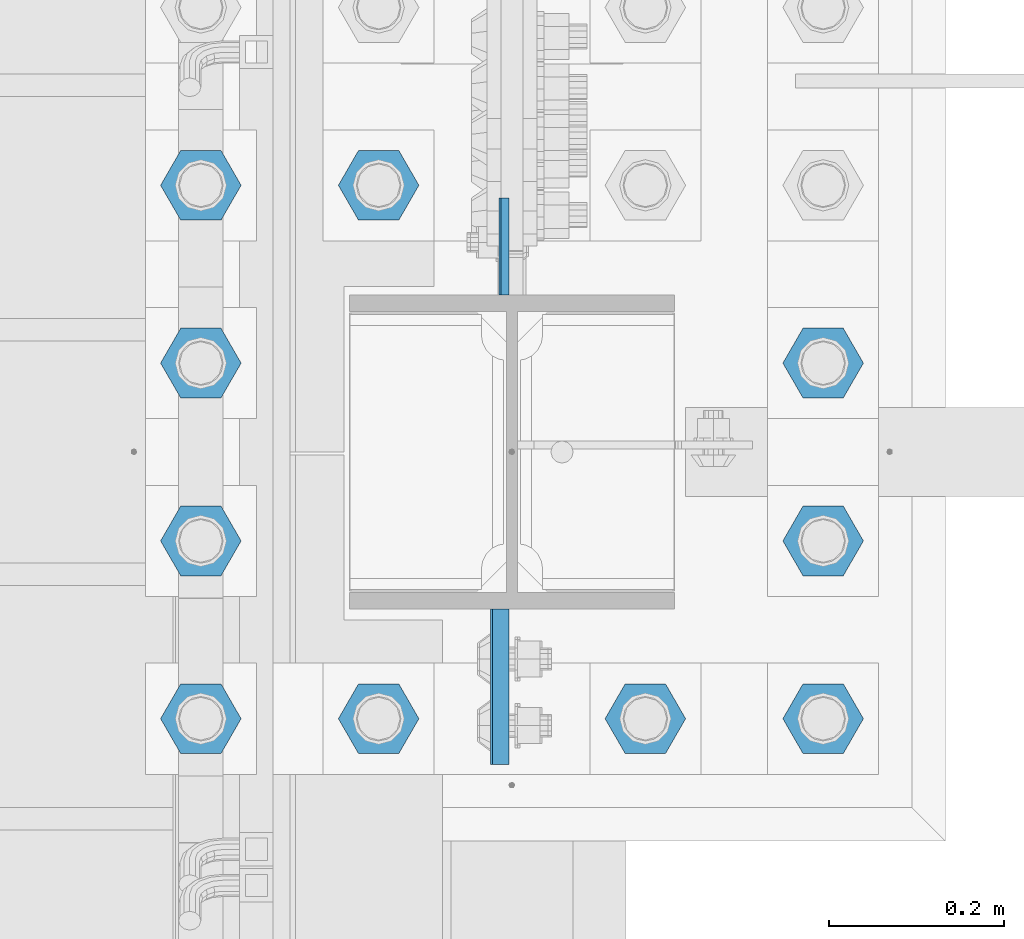
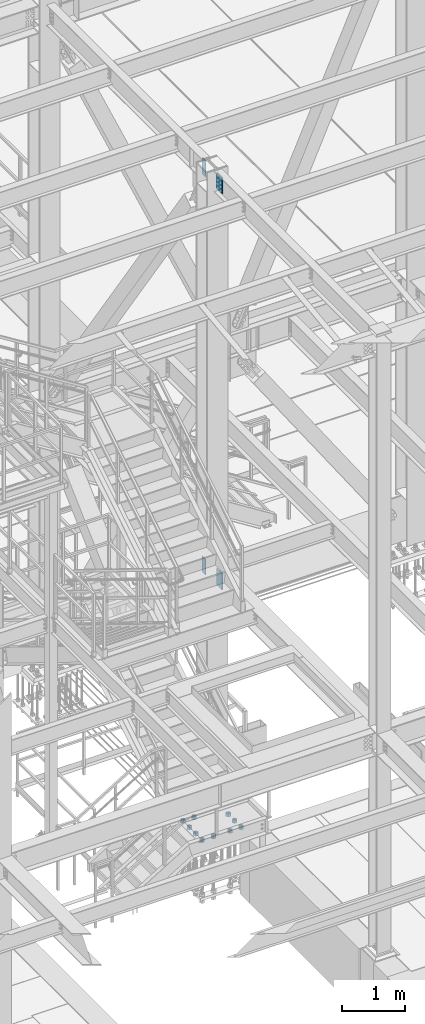
# One storey, part 1480 of 3843: 14 columns, 2 elements without a shape of their own.
"""IFC2X3 building model written with IfcOpenShell, lengths in millimetres."""

from ifc_helpers import new_model, si_unit, frame, origin_with_axes, place, context, subcontext, project, spatial, faceted_brep, material, type_object, element, aggregate, save


model = new_model("IFC2X3")

# Units and contexts
model_context = context("Model", 3, precision=1e-05, world=origin_with_axes())
body_context = subcontext(model_context, "Body", "Model", "MODEL_VIEW")
ifc_project = project(units=[si_unit("LENGTHUNIT", "METRE", prefix="MILLI"), si_unit("AREAUNIT", "SQUARE_METRE"), si_unit("VOLUMEUNIT", "CUBIC_METRE"), si_unit("MASSUNIT", "GRAM", prefix="KILO"), si_unit("TIMEUNIT", "SECOND"), si_unit("PLANEANGLEUNIT", "RADIAN"), si_unit("SOLIDANGLEUNIT", "STERADIAN"), si_unit("THERMODYNAMICTEMPERATUREUNIT", "DEGREE_CELSIUS"), si_unit("LUMINOUSINTENSITYUNIT", "LUMEN")], contexts=[model_context])

# Site, building, storey
site_placement = place(None, origin_with_axes())
site = spatial("IfcSite", under=ifc_project, at=site_placement, CompositionType="ELEMENT")
building_placement = place(site_placement, origin_with_axes())
building = spatial("IfcBuilding", under=site, at=building_placement, Name="Undefined", CompositionType="ELEMENT")
storey_placement = place(building_placement, origin_with_axes())
storey = spatial("IfcBuildingStorey", under=building, at=storey_placement, Name="Undefined", CompositionType="ELEMENT", Elevation=0.0)

# Assembly, columns
assembly_1_placement = place(storey_placement, origin_with_axes())
assembly_1 = element("IfcElementAssembly", 1, at=assembly_1_placement, inside=storey, Name="COLUMN", AssemblyPlace="NOTDEFINED", PredefinedType="RIGID_FRAME")
ifc_material_1 = material(Name="STEEL/A572-50")
column_type_1 = type_object("IfcColumnType", PredefinedType="NOTDEFINED")
column_1_placement = place(assembly_1_placement, frame((55922.8625, 20542.25, 42108.4374991957), z_axis=(0.0, -1.0, 0.0), x_axis=(0.0, 0.0, 1.0)))
column_1 = element("IfcColumn", 2, at=column_1_placement, type_object=column_type_1, material=ifc_material_1, Name="PLATE", context=body_context, shape_type="Brep", body=[
    faceted_brep([(0.0, 4.76249999999709, -55.5625), (0.0, 4.76249999999709, 55.5625), (317.5, 4.76249999999709, 55.5625), (317.5, 4.76249999999709, -55.5625), (0.0, -4.76249999999709, 55.5625), (317.5, -4.76249999999709, 55.5625), (0.0, -4.76249999999709, -55.5625), (317.5, -4.76249999999709, -55.5625)], [[[0, 1, 2, 3]], [[1, 4, 5, 2]], [[4, 6, 7, 5]], [[6, 0, 3, 7]], [[5, 7, 3, 2]], [[6, 4, 1, 0]]]),
])
column_2_placement = place(assembly_1_placement, frame((55920.48125, 20542.25, 34426.525), z_axis=(0.0, -1.0, 0.0), x_axis=(0.0, 0.0, 1.0)))
column_2 = element("IfcColumn", 3, at=column_2_placement, type_object=column_type_1, material=ifc_material_1, Name="PLATE", context=body_context, shape_type="Brep", body=[
    faceted_brep([(0.0, 4.76249999999709, -55.5625), (0.0, 4.76249999999709, 55.5625), (304.800000000003, 4.76249999999709, 55.5625), (304.800000000003, 4.76249999999709, -55.5625), (0.0, -4.76249999999709, 55.5625), (304.800000000003, -4.76249999999709, 55.5625), (0.0, -4.76249999999709, -55.5625), (304.800000000003, -4.76249999999709, -55.5625)], [[[0, 1, 2, 3]], [[1, 4, 5, 2]], [[4, 6, 7, 5]], [[6, 0, 3, 7]], [[5, 7, 3, 2]], [[6, 4, 1, 0]]]),
])
column_type_2 = type_object("IfcColumnType", PredefinedType="NOTDEFINED")
column_3_placement = place(assembly_1_placement, frame((55918.1, 20039.0125, 42113.1999993376), z_axis=(0.0, 1.0, 0.0), x_axis=(0.0, 0.0, 1.0)))
column_3 = element("IfcColumn", 4, at=column_3_placement, type_object=column_type_2, material=ifc_material_1, Name="PLATE", context=body_context, shape_type="Brep", body=[
    faceted_brep([(0.0, 9.52500000000146, -88.9000000000015), (0.0, 9.52500000000146, 88.9000000000015), (317.5, 9.52500000000146, 88.9000000000015), (317.5, 9.52500000000146, -88.9000000000015), (0.0, -9.52500000000146, 88.9000000000015), (317.5, -9.52500000000146, 88.9000000000015), (0.0, -9.52500000000146, -88.9000000000015), (317.5, -9.52500000000146, -88.9000000000015)], [[[0, 1, 2, 3]], [[1, 4, 5, 2]], [[4, 6, 7, 5]], [[6, 0, 3, 7]], [[5, 7, 3, 2]], [[6, 4, 1, 0]]]),
])
column_4_placement = place(assembly_1_placement, frame((55915.71875, 20039.0125, 34461.4499993376), z_axis=(0.0, 1.0, 0.0), x_axis=(0.0, 0.0, 1.0)))
column_4 = element("IfcColumn", 5, at=column_4_placement, type_object=column_type_2, material=ifc_material_1, Name="PLATE", context=body_context, shape_type="Brep", body=[
    faceted_brep([(0.0, 9.52500000000146, -88.9000000000015), (0.0, 9.52500000000146, 88.9000000000015), (317.5, 9.52500000000146, 88.9000000000015), (317.5, 9.52500000000146, -88.9000000000015), (0.0, -9.52500000000146, 88.9000000000015), (317.5, -9.52500000000146, 88.9000000000015), (0.0, -9.52500000000146, -88.9000000000015), (317.5, -9.52500000000146, -88.9000000000015)], [[[0, 1, 2, 3]], [[1, 4, 5, 2]], [[4, 6, 7, 5]], [[6, 0, 3, 7]], [[5, 7, 3, 2]], [[6, 4, 1, 0]]]),
])
aggregate(assembly_1, [column_1, column_3, column_2, column_4])

assembly_2_placement = place(storey_placement, origin_with_axes())
assembly_2 = element("IfcElementAssembly", 6, at=assembly_2_placement, inside=storey, Name="TEMPLATE", AssemblyPlace="NOTDEFINED", PredefinedType="RIGID_FRAME")
ifc_material_2 = material(Name="STEEL/A36")
column_type_3 = type_object("IfcColumnType", Name="2_HEAVY_HEX_NUT", PredefinedType="NOTDEFINED")
column_5_placement = place(assembly_2_placement, frame((55575.2, 20002.5, 29749.75), z_axis=(0.0, -1.0, 0.0), x_axis=(0.0, 0.0, -1.0)))
column_5 = element("IfcColumn", 7, at=column_5_placement, type_object=column_type_3, material=ifc_material_2, Name="NUT", ObjectType="2_HEAVY_HEX_NUT", context=body_context, shape_type="Brep", body=[
    faceted_brep([(0.0, -46.0369987487793, 0.0), (0.0, -23.0184993743896, -39.869213104248), (50.7999999999993, -23.0184993743896, -39.869213104248), (50.7999999999993, -46.0369987487793, 0.0), (0.0, 23.0184993743896, -39.869213104248), (50.7999999999993, 23.0184993743896, -39.869213104248), (0.0, 46.0369987487793, 0.0), (50.7999999999993, 46.0369987487793, 0.0), (0.0, 23.0184993743896, 39.869213104248), (50.7999999999993, 23.0184993743896, 39.869213104248), (0.0, -23.0184993743896, 39.869213104248), (50.7999999999993, -23.0184993743896, 39.869213104248), (0.0, 0.0, 26.1940002441406), (0.0, 11.3650617044477, 23.5999013092805), (50.7999999999993, 11.3650617044477, 23.5999013092805), (50.7999999999993, 0.0, 26.1940002441406), (0.0, 20.4791109456419, 16.3316083006721), (50.7999999999993, 20.4791109456419, 16.3316083006721), (0.0, 25.5370200498292, 5.82867859874386), (50.7999999999993, 25.5370200498292, 5.82867859874386), (0.0, 25.5370200498292, -5.82867859874386), (50.7999999999993, 25.5370200498292, -5.82867859874386), (0.0, 20.4791109456419, -16.3316083006721), (50.7999999999993, 20.4791109456419, -16.3316083006721), (0.0, 11.3650617044477, -23.5999013092805), (50.7999999999993, 11.3650617044477, -23.5999013092805), (0.0, 0.0, -26.1940002441406), (50.7999999999993, 0.0, -26.1940002441406), (0.0, -11.3650617044477, -23.5999013092805), (50.7999999999993, -11.3650617044477, -23.5999013092805), (0.0, -20.4791109456419, -16.3316083006721), (50.7999999999993, -20.4791109456419, -16.3316083006721), (0.0, -25.5370200498292, -5.82867859874386), (50.7999999999993, -25.5370200498292, -5.82867859874386), (0.0, -25.5370200498292, 5.82867859874386), (50.7999999999993, -25.5370200498292, 5.82867859874386), (0.0, -20.4791109456419, 16.3316083006721), (50.7999999999993, -20.4791109456419, 16.3316083006721), (0.0, -11.3650617044477, 23.5999013092805), (50.7999999999993, -11.3650617044477, 23.5999013092805)], [[[0, 1, 2, 3]], [[1, 4, 5, 2]], [[4, 6, 7, 5]], [[6, 8, 9, 7]], [[8, 10, 11, 9]], [[10, 0, 3, 11]], [[12, 13, 14, 15]], [[13, 16, 17, 14]], [[16, 18, 19, 17]], [[18, 20, 21, 19]], [[20, 22, 23, 21]], [[22, 24, 25, 23]], [[24, 26, 27, 25]], [[26, 28, 29, 27]], [[28, 30, 31, 29]], [[30, 32, 33, 31]], [[32, 34, 35, 33]], [[34, 36, 37, 35]], [[36, 38, 39, 37]], [[38, 12, 15, 39]], [[5, 7, 9, 11, 3, 2], [17, 19, 21, 23, 25, 27, 29, 31, 33, 35, 37, 39, 15, 14]], [[10, 8, 6, 4, 1, 0], [38, 36, 34, 32, 30, 28, 26, 24, 22, 20, 18, 16, 13, 12]]]),
])
column_6_placement = place(assembly_2_placement, frame((55778.4, 20002.5, 29749.75), z_axis=(0.0, -1.0, 0.0), x_axis=(0.0, 0.0, -1.0)))
column_6 = element("IfcColumn", 8, at=column_6_placement, type_object=column_type_3, material=ifc_material_2, Name="NUT", ObjectType="2_HEAVY_HEX_NUT", context=body_context, shape_type="Brep", body=[
    faceted_brep([(0.0, -46.0369987487793, 0.0), (0.0, -23.0184993743896, -39.869213104248), (50.7999999999993, -23.0184993743896, -39.869213104248), (50.7999999999993, -46.0369987487793, 0.0), (0.0, 23.0184993743896, -39.869213104248), (50.7999999999993, 23.0184993743896, -39.869213104248), (0.0, 46.0369987487793, 0.0), (50.7999999999993, 46.0369987487793, 0.0), (0.0, 23.0184993743896, 39.869213104248), (50.7999999999993, 23.0184993743896, 39.869213104248), (0.0, -23.0184993743896, 39.869213104248), (50.7999999999993, -23.0184993743896, 39.869213104248), (0.0, 0.0, 26.1940002441406), (0.0, 11.3650617044477, 23.5999013092805), (50.7999999999993, 11.3650617044477, 23.5999013092805), (50.7999999999993, 0.0, 26.1940002441406), (0.0, 20.4791109456419, 16.3316083006721), (50.7999999999993, 20.4791109456419, 16.3316083006721), (0.0, 25.5370200498292, 5.82867859874386), (50.7999999999993, 25.5370200498292, 5.82867859874386), (0.0, 25.5370200498292, -5.82867859874386), (50.7999999999993, 25.5370200498292, -5.82867859874386), (0.0, 20.4791109456419, -16.3316083006721), (50.7999999999993, 20.4791109456419, -16.3316083006721), (0.0, 11.3650617044477, -23.5999013092805), (50.7999999999993, 11.3650617044477, -23.5999013092805), (0.0, 0.0, -26.1940002441406), (50.7999999999993, 0.0, -26.1940002441406), (0.0, -11.3650617044477, -23.5999013092805), (50.7999999999993, -11.3650617044477, -23.5999013092805), (0.0, -20.4791109456419, -16.3316083006721), (50.7999999999993, -20.4791109456419, -16.3316083006721), (0.0, -25.5370200498292, -5.82867859874386), (50.7999999999993, -25.5370200498292, -5.82867859874386), (0.0, -25.5370200498292, 5.82867859874386), (50.7999999999993, -25.5370200498292, 5.82867859874386), (0.0, -20.4791109456419, 16.3316083006721), (50.7999999999993, -20.4791109456419, 16.3316083006721), (0.0, -11.3650617044477, 23.5999013092805), (50.7999999999993, -11.3650617044477, 23.5999013092805)], [[[0, 1, 2, 3]], [[1, 4, 5, 2]], [[4, 6, 7, 5]], [[6, 8, 9, 7]], [[8, 10, 11, 9]], [[10, 0, 3, 11]], [[12, 13, 14, 15]], [[13, 16, 17, 14]], [[16, 18, 19, 17]], [[18, 20, 21, 19]], [[20, 22, 23, 21]], [[22, 24, 25, 23]], [[24, 26, 27, 25]], [[26, 28, 29, 27]], [[28, 30, 31, 29]], [[30, 32, 33, 31]], [[32, 34, 35, 33]], [[34, 36, 37, 35]], [[36, 38, 39, 37]], [[38, 12, 15, 39]], [[5, 7, 9, 11, 3, 2], [17, 19, 21, 23, 25, 27, 29, 31, 33, 35, 37, 39, 15, 14]], [[10, 8, 6, 4, 1, 0], [38, 36, 34, 32, 30, 28, 26, 24, 22, 20, 18, 16, 13, 12]]]),
])
column_7_placement = place(assembly_2_placement, frame((56083.2, 20002.5, 29749.75), z_axis=(0.0, 1.0, 0.0), x_axis=(0.0, 0.0, -1.0)))
column_7 = element("IfcColumn", 9, at=column_7_placement, type_object=column_type_3, material=ifc_material_2, Name="NUT", ObjectType="2_HEAVY_HEX_NUT", context=body_context, shape_type="Brep", body=[
    faceted_brep([(0.0, -46.0369987487793, 0.0), (0.0, -23.0184993743896, -39.869213104248), (50.7999999999993, -23.0184993743896, -39.869213104248), (50.7999999999993, -46.0369987487793, 0.0), (0.0, 23.0184993743896, -39.869213104248), (50.7999999999993, 23.0184993743896, -39.869213104248), (0.0, 46.0369987487793, 0.0), (50.7999999999993, 46.0369987487793, 0.0), (0.0, 23.0184993743896, 39.869213104248), (50.7999999999993, 23.0184993743896, 39.869213104248), (0.0, -23.0184993743896, 39.869213104248), (50.7999999999993, -23.0184993743896, 39.869213104248), (0.0, 0.0, 26.1940002441406), (0.0, 11.3650617044477, 23.5999013092805), (50.7999999999993, 11.3650617044477, 23.5999013092805), (50.7999999999993, 0.0, 26.1940002441406), (0.0, 20.4791109456419, 16.3316083006721), (50.7999999999993, 20.4791109456419, 16.3316083006721), (0.0, 25.5370200498292, 5.82867859874386), (50.7999999999993, 25.5370200498292, 5.82867859874386), (0.0, 25.5370200498292, -5.82867859874386), (50.7999999999993, 25.5370200498292, -5.82867859874386), (0.0, 20.4791109456419, -16.3316083006721), (50.7999999999993, 20.4791109456419, -16.3316083006721), (0.0, 11.3650617044477, -23.5999013092805), (50.7999999999993, 11.3650617044477, -23.5999013092805), (0.0, 0.0, -26.1940002441406), (50.7999999999993, 0.0, -26.1940002441406), (0.0, -11.3650617044477, -23.5999013092805), (50.7999999999993, -11.3650617044477, -23.5999013092805), (0.0, -20.4791109456419, -16.3316083006721), (50.7999999999993, -20.4791109456419, -16.3316083006721), (0.0, -25.5370200498292, -5.82867859874386), (50.7999999999993, -25.5370200498292, -5.82867859874386), (0.0, -25.5370200498292, 5.82867859874386), (50.7999999999993, -25.5370200498292, 5.82867859874386), (0.0, -20.4791109456419, 16.3316083006721), (50.7999999999993, -20.4791109456419, 16.3316083006721), (0.0, -11.3650617044477, 23.5999013092805), (50.7999999999993, -11.3650617044477, 23.5999013092805)], [[[0, 1, 2, 3]], [[1, 4, 5, 2]], [[4, 6, 7, 5]], [[6, 8, 9, 7]], [[8, 10, 11, 9]], [[10, 0, 3, 11]], [[12, 13, 14, 15]], [[13, 16, 17, 14]], [[16, 18, 19, 17]], [[18, 20, 21, 19]], [[20, 22, 23, 21]], [[22, 24, 25, 23]], [[24, 26, 27, 25]], [[26, 28, 29, 27]], [[28, 30, 31, 29]], [[30, 32, 33, 31]], [[32, 34, 35, 33]], [[34, 36, 37, 35]], [[36, 38, 39, 37]], [[38, 12, 15, 39]], [[5, 7, 9, 11, 3, 2], [17, 19, 21, 23, 25, 27, 29, 31, 33, 35, 37, 39, 15, 14]], [[10, 8, 6, 4, 1, 0], [38, 36, 34, 32, 30, 28, 26, 24, 22, 20, 18, 16, 13, 12]]]),
])
column_8_placement = place(assembly_2_placement, frame((56286.4, 20002.5, 29749.75), z_axis=(0.0, 1.0, 0.0), x_axis=(0.0, 0.0, -1.0)))
column_8 = element("IfcColumn", 10, at=column_8_placement, type_object=column_type_3, material=ifc_material_2, Name="NUT", ObjectType="2_HEAVY_HEX_NUT", context=body_context, shape_type="Brep", body=[
    faceted_brep([(0.0, -46.0369987487793, 0.0), (0.0, -23.0184993743896, -39.869213104248), (50.7999999999993, -23.0184993743896, -39.869213104248), (50.7999999999993, -46.0369987487793, 0.0), (0.0, 23.0184993743896, -39.869213104248), (50.7999999999993, 23.0184993743896, -39.869213104248), (0.0, 46.0369987487793, 0.0), (50.7999999999993, 46.0369987487793, 0.0), (0.0, 23.0184993743896, 39.869213104248), (50.7999999999993, 23.0184993743896, 39.869213104248), (0.0, -23.0184993743896, 39.869213104248), (50.7999999999993, -23.0184993743896, 39.869213104248), (0.0, 0.0, 26.1940002441406), (0.0, 11.3650617044477, 23.5999013092805), (50.7999999999993, 11.3650617044477, 23.5999013092805), (50.7999999999993, 0.0, 26.1940002441406), (0.0, 20.4791109456419, 16.3316083006721), (50.7999999999993, 20.4791109456419, 16.3316083006721), (0.0, 25.5370200498292, 5.82867859874386), (50.7999999999993, 25.5370200498292, 5.82867859874386), (0.0, 25.5370200498292, -5.82867859874386), (50.7999999999993, 25.5370200498292, -5.82867859874386), (0.0, 20.4791109456419, -16.3316083006721), (50.7999999999993, 20.4791109456419, -16.3316083006721), (0.0, 11.3650617044477, -23.5999013092805), (50.7999999999993, 11.3650617044477, -23.5999013092805), (0.0, 0.0, -26.1940002441406), (50.7999999999993, 0.0, -26.1940002441406), (0.0, -11.3650617044477, -23.5999013092805), (50.7999999999993, -11.3650617044477, -23.5999013092805), (0.0, -20.4791109456419, -16.3316083006721), (50.7999999999993, -20.4791109456419, -16.3316083006721), (0.0, -25.5370200498292, -5.82867859874386), (50.7999999999993, -25.5370200498292, -5.82867859874386), (0.0, -25.5370200498292, 5.82867859874386), (50.7999999999993, -25.5370200498292, 5.82867859874386), (0.0, -20.4791109456419, 16.3316083006721), (50.7999999999993, -20.4791109456419, 16.3316083006721), (0.0, -11.3650617044477, 23.5999013092805), (50.7999999999993, -11.3650617044477, 23.5999013092805)], [[[0, 1, 2, 3]], [[1, 4, 5, 2]], [[4, 6, 7, 5]], [[6, 8, 9, 7]], [[8, 10, 11, 9]], [[10, 0, 3, 11]], [[12, 13, 14, 15]], [[13, 16, 17, 14]], [[16, 18, 19, 17]], [[18, 20, 21, 19]], [[20, 22, 23, 21]], [[22, 24, 25, 23]], [[24, 26, 27, 25]], [[26, 28, 29, 27]], [[28, 30, 31, 29]], [[30, 32, 33, 31]], [[32, 34, 35, 33]], [[34, 36, 37, 35]], [[36, 38, 39, 37]], [[38, 12, 15, 39]], [[5, 7, 9, 11, 3, 2], [17, 19, 21, 23, 25, 27, 29, 31, 33, 35, 37, 39, 15, 14]], [[10, 8, 6, 4, 1, 0], [38, 36, 34, 32, 30, 28, 26, 24, 22, 20, 18, 16, 13, 12]]]),
])
column_9_placement = place(assembly_2_placement, frame((55575.2, 20205.7, 29749.75), z_axis=(0.0, -1.0, 0.0), x_axis=(0.0, 0.0, -1.0)))
column_9 = element("IfcColumn", 11, at=column_9_placement, type_object=column_type_3, material=ifc_material_2, Name="NUT", ObjectType="2_HEAVY_HEX_NUT", context=body_context, shape_type="Brep", body=[
    faceted_brep([(0.0, -46.0369987487793, 0.0), (0.0, -23.0184993743896, -39.869213104248), (50.7999999999993, -23.0184993743896, -39.869213104248), (50.7999999999993, -46.0369987487793, 0.0), (0.0, 23.0184993743896, -39.869213104248), (50.7999999999993, 23.0184993743896, -39.869213104248), (0.0, 46.0369987487793, 0.0), (50.7999999999993, 46.0369987487793, 0.0), (0.0, 23.0184993743896, 39.869213104248), (50.7999999999993, 23.0184993743896, 39.869213104248), (0.0, -23.0184993743896, 39.869213104248), (50.7999999999993, -23.0184993743896, 39.869213104248), (0.0, 0.0, 26.1940002441406), (0.0, 11.3650617044477, 23.5999013092805), (50.7999999999993, 11.3650617044477, 23.5999013092805), (50.7999999999993, 0.0, 26.1940002441406), (0.0, 20.4791109456419, 16.3316083006721), (50.7999999999993, 20.4791109456419, 16.3316083006721), (0.0, 25.5370200498292, 5.82867859874386), (50.7999999999993, 25.5370200498292, 5.82867859874386), (0.0, 25.5370200498292, -5.82867859874386), (50.7999999999993, 25.5370200498292, -5.82867859874386), (0.0, 20.4791109456419, -16.3316083006721), (50.7999999999993, 20.4791109456419, -16.3316083006721), (0.0, 11.3650617044477, -23.5999013092805), (50.7999999999993, 11.3650617044477, -23.5999013092805), (0.0, 0.0, -26.1940002441406), (50.7999999999993, 0.0, -26.1940002441406), (0.0, -11.3650617044477, -23.5999013092805), (50.7999999999993, -11.3650617044477, -23.5999013092805), (0.0, -20.4791109456419, -16.3316083006721), (50.7999999999993, -20.4791109456419, -16.3316083006721), (0.0, -25.5370200498292, -5.82867859874386), (50.7999999999993, -25.5370200498292, -5.82867859874386), (0.0, -25.5370200498292, 5.82867859874386), (50.7999999999993, -25.5370200498292, 5.82867859874386), (0.0, -20.4791109456419, 16.3316083006721), (50.7999999999993, -20.4791109456419, 16.3316083006721), (0.0, -11.3650617044477, 23.5999013092805), (50.7999999999993, -11.3650617044477, 23.5999013092805)], [[[0, 1, 2, 3]], [[1, 4, 5, 2]], [[4, 6, 7, 5]], [[6, 8, 9, 7]], [[8, 10, 11, 9]], [[10, 0, 3, 11]], [[12, 13, 14, 15]], [[13, 16, 17, 14]], [[16, 18, 19, 17]], [[18, 20, 21, 19]], [[20, 22, 23, 21]], [[22, 24, 25, 23]], [[24, 26, 27, 25]], [[26, 28, 29, 27]], [[28, 30, 31, 29]], [[30, 32, 33, 31]], [[32, 34, 35, 33]], [[34, 36, 37, 35]], [[36, 38, 39, 37]], [[38, 12, 15, 39]], [[5, 7, 9, 11, 3, 2], [17, 19, 21, 23, 25, 27, 29, 31, 33, 35, 37, 39, 15, 14]], [[10, 8, 6, 4, 1, 0], [38, 36, 34, 32, 30, 28, 26, 24, 22, 20, 18, 16, 13, 12]]]),
])
column_10_placement = place(assembly_2_placement, frame((56286.4, 20205.7, 29749.75), z_axis=(0.0, 1.0, 0.0), x_axis=(0.0, 0.0, -1.0)))
column_10 = element("IfcColumn", 12, at=column_10_placement, type_object=column_type_3, material=ifc_material_2, Name="NUT", ObjectType="2_HEAVY_HEX_NUT", context=body_context, shape_type="Brep", body=[
    faceted_brep([(0.0, -46.0369987487793, 0.0), (0.0, -23.0184993743896, -39.869213104248), (50.7999999999993, -23.0184993743896, -39.869213104248), (50.7999999999993, -46.0369987487793, 0.0), (0.0, 23.0184993743896, -39.869213104248), (50.7999999999993, 23.0184993743896, -39.869213104248), (0.0, 46.0369987487793, 0.0), (50.7999999999993, 46.0369987487793, 0.0), (0.0, 23.0184993743896, 39.869213104248), (50.7999999999993, 23.0184993743896, 39.869213104248), (0.0, -23.0184993743896, 39.869213104248), (50.7999999999993, -23.0184993743896, 39.869213104248), (0.0, 0.0, 26.1940002441406), (0.0, 11.3650617044477, 23.5999013092805), (50.7999999999993, 11.3650617044477, 23.5999013092805), (50.7999999999993, 0.0, 26.1940002441406), (0.0, 20.4791109456419, 16.3316083006721), (50.7999999999993, 20.4791109456419, 16.3316083006721), (0.0, 25.5370200498292, 5.82867859874386), (50.7999999999993, 25.5370200498292, 5.82867859874386), (0.0, 25.5370200498292, -5.82867859874386), (50.7999999999993, 25.5370200498292, -5.82867859874386), (0.0, 20.4791109456419, -16.3316083006721), (50.7999999999993, 20.4791109456419, -16.3316083006721), (0.0, 11.3650617044477, -23.5999013092805), (50.7999999999993, 11.3650617044477, -23.5999013092805), (0.0, 0.0, -26.1940002441406), (50.7999999999993, 0.0, -26.1940002441406), (0.0, -11.3650617044477, -23.5999013092805), (50.7999999999993, -11.3650617044477, -23.5999013092805), (0.0, -20.4791109456419, -16.3316083006721), (50.7999999999993, -20.4791109456419, -16.3316083006721), (0.0, -25.5370200498292, -5.82867859874386), (50.7999999999993, -25.5370200498292, -5.82867859874386), (0.0, -25.5370200498292, 5.82867859874386), (50.7999999999993, -25.5370200498292, 5.82867859874386), (0.0, -20.4791109456419, 16.3316083006721), (50.7999999999993, -20.4791109456419, 16.3316083006721), (0.0, -11.3650617044477, 23.5999013092805), (50.7999999999993, -11.3650617044477, 23.5999013092805)], [[[0, 1, 2, 3]], [[1, 4, 5, 2]], [[4, 6, 7, 5]], [[6, 8, 9, 7]], [[8, 10, 11, 9]], [[10, 0, 3, 11]], [[12, 13, 14, 15]], [[13, 16, 17, 14]], [[16, 18, 19, 17]], [[18, 20, 21, 19]], [[20, 22, 23, 21]], [[22, 24, 25, 23]], [[24, 26, 27, 25]], [[26, 28, 29, 27]], [[28, 30, 31, 29]], [[30, 32, 33, 31]], [[32, 34, 35, 33]], [[34, 36, 37, 35]], [[36, 38, 39, 37]], [[38, 12, 15, 39]], [[5, 7, 9, 11, 3, 2], [17, 19, 21, 23, 25, 27, 29, 31, 33, 35, 37, 39, 15, 14]], [[10, 8, 6, 4, 1, 0], [38, 36, 34, 32, 30, 28, 26, 24, 22, 20, 18, 16, 13, 12]]]),
])
column_11_placement = place(assembly_2_placement, frame((55575.2, 20408.9, 29749.75), z_axis=(0.0, -1.0, 0.0), x_axis=(0.0, 0.0, -1.0)))
column_11 = element("IfcColumn", 13, at=column_11_placement, type_object=column_type_3, material=ifc_material_2, Name="NUT", ObjectType="2_HEAVY_HEX_NUT", context=body_context, shape_type="Brep", body=[
    faceted_brep([(0.0, -46.0369987487793, 0.0), (0.0, -23.0184993743896, -39.869213104248), (50.7999999999993, -23.0184993743896, -39.869213104248), (50.7999999999993, -46.0369987487793, 0.0), (0.0, 23.0184993743896, -39.869213104248), (50.7999999999993, 23.0184993743896, -39.869213104248), (0.0, 46.0369987487793, 0.0), (50.7999999999993, 46.0369987487793, 0.0), (0.0, 23.0184993743896, 39.869213104248), (50.7999999999993, 23.0184993743896, 39.869213104248), (0.0, -23.0184993743896, 39.869213104248), (50.7999999999993, -23.0184993743896, 39.869213104248), (0.0, 0.0, 26.1940002441406), (0.0, 11.3650617044477, 23.5999013092805), (50.7999999999993, 11.3650617044477, 23.5999013092805), (50.7999999999993, 0.0, 26.1940002441406), (0.0, 20.4791109456419, 16.3316083006721), (50.7999999999993, 20.4791109456419, 16.3316083006721), (0.0, 25.5370200498292, 5.82867859874386), (50.7999999999993, 25.5370200498292, 5.82867859874386), (0.0, 25.5370200498292, -5.82867859874386), (50.7999999999993, 25.5370200498292, -5.82867859874386), (0.0, 20.4791109456419, -16.3316083006721), (50.7999999999993, 20.4791109456419, -16.3316083006721), (0.0, 11.3650617044477, -23.5999013092805), (50.7999999999993, 11.3650617044477, -23.5999013092805), (0.0, 0.0, -26.1940002441406), (50.7999999999993, 0.0, -26.1940002441406), (0.0, -11.3650617044477, -23.5999013092805), (50.7999999999993, -11.3650617044477, -23.5999013092805), (0.0, -20.4791109456419, -16.3316083006721), (50.7999999999993, -20.4791109456419, -16.3316083006721), (0.0, -25.5370200498292, -5.82867859874386), (50.7999999999993, -25.5370200498292, -5.82867859874386), (0.0, -25.5370200498292, 5.82867859874386), (50.7999999999993, -25.5370200498292, 5.82867859874386), (0.0, -20.4791109456419, 16.3316083006721), (50.7999999999993, -20.4791109456419, 16.3316083006721), (0.0, -11.3650617044477, 23.5999013092805), (50.7999999999993, -11.3650617044477, 23.5999013092805)], [[[0, 1, 2, 3]], [[1, 4, 5, 2]], [[4, 6, 7, 5]], [[6, 8, 9, 7]], [[8, 10, 11, 9]], [[10, 0, 3, 11]], [[12, 13, 14, 15]], [[13, 16, 17, 14]], [[16, 18, 19, 17]], [[18, 20, 21, 19]], [[20, 22, 23, 21]], [[22, 24, 25, 23]], [[24, 26, 27, 25]], [[26, 28, 29, 27]], [[28, 30, 31, 29]], [[30, 32, 33, 31]], [[32, 34, 35, 33]], [[34, 36, 37, 35]], [[36, 38, 39, 37]], [[38, 12, 15, 39]], [[5, 7, 9, 11, 3, 2], [17, 19, 21, 23, 25, 27, 29, 31, 33, 35, 37, 39, 15, 14]], [[10, 8, 6, 4, 1, 0], [38, 36, 34, 32, 30, 28, 26, 24, 22, 20, 18, 16, 13, 12]]]),
])
column_12_placement = place(assembly_2_placement, frame((56286.4, 20408.9, 29749.75), z_axis=(0.0, 1.0, 0.0), x_axis=(0.0, 0.0, -1.0)))
column_12 = element("IfcColumn", 14, at=column_12_placement, type_object=column_type_3, material=ifc_material_2, Name="NUT", ObjectType="2_HEAVY_HEX_NUT", context=body_context, shape_type="Brep", body=[
    faceted_brep([(0.0, -46.0369987487793, 0.0), (0.0, -23.0184993743896, -39.869213104248), (50.7999999999993, -23.0184993743896, -39.869213104248), (50.7999999999993, -46.0369987487793, 0.0), (0.0, 23.0184993743896, -39.869213104248), (50.7999999999993, 23.0184993743896, -39.869213104248), (0.0, 46.0369987487793, 0.0), (50.7999999999993, 46.0369987487793, 0.0), (0.0, 23.0184993743896, 39.869213104248), (50.7999999999993, 23.0184993743896, 39.869213104248), (0.0, -23.0184993743896, 39.869213104248), (50.7999999999993, -23.0184993743896, 39.869213104248), (0.0, 0.0, 26.1940002441406), (0.0, 11.3650617044477, 23.5999013092805), (50.7999999999993, 11.3650617044477, 23.5999013092805), (50.7999999999993, 0.0, 26.1940002441406), (0.0, 20.4791109456419, 16.3316083006721), (50.7999999999993, 20.4791109456419, 16.3316083006721), (0.0, 25.5370200498292, 5.82867859874386), (50.7999999999993, 25.5370200498292, 5.82867859874386), (0.0, 25.5370200498292, -5.82867859874386), (50.7999999999993, 25.5370200498292, -5.82867859874386), (0.0, 20.4791109456419, -16.3316083006721), (50.7999999999993, 20.4791109456419, -16.3316083006721), (0.0, 11.3650617044477, -23.5999013092805), (50.7999999999993, 11.3650617044477, -23.5999013092805), (0.0, 0.0, -26.1940002441406), (50.7999999999993, 0.0, -26.1940002441406), (0.0, -11.3650617044477, -23.5999013092805), (50.7999999999993, -11.3650617044477, -23.5999013092805), (0.0, -20.4791109456419, -16.3316083006721), (50.7999999999993, -20.4791109456419, -16.3316083006721), (0.0, -25.5370200498292, -5.82867859874386), (50.7999999999993, -25.5370200498292, -5.82867859874386), (0.0, -25.5370200498292, 5.82867859874386), (50.7999999999993, -25.5370200498292, 5.82867859874386), (0.0, -20.4791109456419, 16.3316083006721), (50.7999999999993, -20.4791109456419, 16.3316083006721), (0.0, -11.3650617044477, 23.5999013092805), (50.7999999999993, -11.3650617044477, 23.5999013092805)], [[[0, 1, 2, 3]], [[1, 4, 5, 2]], [[4, 6, 7, 5]], [[6, 8, 9, 7]], [[8, 10, 11, 9]], [[10, 0, 3, 11]], [[12, 13, 14, 15]], [[13, 16, 17, 14]], [[16, 18, 19, 17]], [[18, 20, 21, 19]], [[20, 22, 23, 21]], [[22, 24, 25, 23]], [[24, 26, 27, 25]], [[26, 28, 29, 27]], [[28, 30, 31, 29]], [[30, 32, 33, 31]], [[32, 34, 35, 33]], [[34, 36, 37, 35]], [[36, 38, 39, 37]], [[38, 12, 15, 39]], [[5, 7, 9, 11, 3, 2], [17, 19, 21, 23, 25, 27, 29, 31, 33, 35, 37, 39, 15, 14]], [[10, 8, 6, 4, 1, 0], [38, 36, 34, 32, 30, 28, 26, 24, 22, 20, 18, 16, 13, 12]]]),
])
column_13_placement = place(assembly_2_placement, frame((55575.2, 20612.1, 29749.75), z_axis=(0.0, -1.0, 0.0), x_axis=(0.0, 0.0, -1.0)))
column_13 = element("IfcColumn", 15, at=column_13_placement, type_object=column_type_3, material=ifc_material_2, Name="NUT", ObjectType="2_HEAVY_HEX_NUT", context=body_context, shape_type="Brep", body=[
    faceted_brep([(0.0, -46.0369987487793, 0.0), (0.0, -23.0184993743896, -39.869213104248), (50.7999999999993, -23.0184993743896, -39.869213104248), (50.7999999999993, -46.0369987487793, 0.0), (0.0, 23.0184993743896, -39.869213104248), (50.7999999999993, 23.0184993743896, -39.869213104248), (0.0, 46.0369987487793, 0.0), (50.7999999999993, 46.0369987487793, 0.0), (0.0, 23.0184993743896, 39.869213104248), (50.7999999999993, 23.0184993743896, 39.869213104248), (0.0, -23.0184993743896, 39.869213104248), (50.7999999999993, -23.0184993743896, 39.869213104248), (0.0, 0.0, 26.1940002441406), (0.0, 11.3650617044477, 23.5999013092805), (50.7999999999993, 11.3650617044477, 23.5999013092805), (50.7999999999993, 0.0, 26.1940002441406), (0.0, 20.4791109456419, 16.3316083006721), (50.7999999999993, 20.4791109456419, 16.3316083006721), (0.0, 25.5370200498292, 5.82867859874386), (50.7999999999993, 25.5370200498292, 5.82867859874386), (0.0, 25.5370200498292, -5.82867859874386), (50.7999999999993, 25.5370200498292, -5.82867859874386), (0.0, 20.4791109456419, -16.3316083006721), (50.7999999999993, 20.4791109456419, -16.3316083006721), (0.0, 11.3650617044477, -23.5999013092805), (50.7999999999993, 11.3650617044477, -23.5999013092805), (0.0, 0.0, -26.1940002441406), (50.7999999999993, 0.0, -26.1940002441406), (0.0, -11.3650617044477, -23.5999013092805), (50.7999999999993, -11.3650617044477, -23.5999013092805), (0.0, -20.4791109456419, -16.3316083006721), (50.7999999999993, -20.4791109456419, -16.3316083006721), (0.0, -25.5370200498292, -5.82867859874386), (50.7999999999993, -25.5370200498292, -5.82867859874386), (0.0, -25.5370200498292, 5.82867859874386), (50.7999999999993, -25.5370200498292, 5.82867859874386), (0.0, -20.4791109456419, 16.3316083006721), (50.7999999999993, -20.4791109456419, 16.3316083006721), (0.0, -11.3650617044477, 23.5999013092805), (50.7999999999993, -11.3650617044477, 23.5999013092805)], [[[0, 1, 2, 3]], [[1, 4, 5, 2]], [[4, 6, 7, 5]], [[6, 8, 9, 7]], [[8, 10, 11, 9]], [[10, 0, 3, 11]], [[12, 13, 14, 15]], [[13, 16, 17, 14]], [[16, 18, 19, 17]], [[18, 20, 21, 19]], [[20, 22, 23, 21]], [[22, 24, 25, 23]], [[24, 26, 27, 25]], [[26, 28, 29, 27]], [[28, 30, 31, 29]], [[30, 32, 33, 31]], [[32, 34, 35, 33]], [[34, 36, 37, 35]], [[36, 38, 39, 37]], [[38, 12, 15, 39]], [[5, 7, 9, 11, 3, 2], [17, 19, 21, 23, 25, 27, 29, 31, 33, 35, 37, 39, 15, 14]], [[10, 8, 6, 4, 1, 0], [38, 36, 34, 32, 30, 28, 26, 24, 22, 20, 18, 16, 13, 12]]]),
])
column_14_placement = place(assembly_2_placement, frame((55778.4, 20612.1, 29749.75), z_axis=(0.0, -1.0, 0.0), x_axis=(0.0, 0.0, -1.0)))
column_14 = element("IfcColumn", 16, at=column_14_placement, type_object=column_type_3, material=ifc_material_2, Name="NUT", ObjectType="2_HEAVY_HEX_NUT", context=body_context, shape_type="Brep", body=[
    faceted_brep([(0.0, -46.0369987487793, 0.0), (0.0, -23.0184993743896, -39.869213104248), (50.7999999999993, -23.0184993743896, -39.869213104248), (50.7999999999993, -46.0369987487793, 0.0), (0.0, 23.0184993743896, -39.869213104248), (50.7999999999993, 23.0184993743896, -39.869213104248), (0.0, 46.0369987487793, 0.0), (50.7999999999993, 46.0369987487793, 0.0), (0.0, 23.0184993743896, 39.869213104248), (50.7999999999993, 23.0184993743896, 39.869213104248), (0.0, -23.0184993743896, 39.869213104248), (50.7999999999993, -23.0184993743896, 39.869213104248), (0.0, 0.0, 26.1940002441406), (0.0, 11.3650617044477, 23.5999013092805), (50.7999999999993, 11.3650617044477, 23.5999013092805), (50.7999999999993, 0.0, 26.1940002441406), (0.0, 20.4791109456419, 16.3316083006721), (50.7999999999993, 20.4791109456419, 16.3316083006721), (0.0, 25.5370200498292, 5.82867859874386), (50.7999999999993, 25.5370200498292, 5.82867859874386), (0.0, 25.5370200498292, -5.82867859874386), (50.7999999999993, 25.5370200498292, -5.82867859874386), (0.0, 20.4791109456419, -16.3316083006721), (50.7999999999993, 20.4791109456419, -16.3316083006721), (0.0, 11.3650617044477, -23.5999013092805), (50.7999999999993, 11.3650617044477, -23.5999013092805), (0.0, 0.0, -26.1940002441406), (50.7999999999993, 0.0, -26.1940002441406), (0.0, -11.3650617044477, -23.5999013092805), (50.7999999999993, -11.3650617044477, -23.5999013092805), (0.0, -20.4791109456419, -16.3316083006721), (50.7999999999993, -20.4791109456419, -16.3316083006721), (0.0, -25.5370200498292, -5.82867859874386), (50.7999999999993, -25.5370200498292, -5.82867859874386), (0.0, -25.5370200498292, 5.82867859874386), (50.7999999999993, -25.5370200498292, 5.82867859874386), (0.0, -20.4791109456419, 16.3316083006721), (50.7999999999993, -20.4791109456419, 16.3316083006721), (0.0, -11.3650617044477, 23.5999013092805), (50.7999999999993, -11.3650617044477, 23.5999013092805)], [[[0, 1, 2, 3]], [[1, 4, 5, 2]], [[4, 6, 7, 5]], [[6, 8, 9, 7]], [[8, 10, 11, 9]], [[10, 0, 3, 11]], [[12, 13, 14, 15]], [[13, 16, 17, 14]], [[16, 18, 19, 17]], [[18, 20, 21, 19]], [[20, 22, 23, 21]], [[22, 24, 25, 23]], [[24, 26, 27, 25]], [[26, 28, 29, 27]], [[28, 30, 31, 29]], [[30, 32, 33, 31]], [[32, 34, 35, 33]], [[34, 36, 37, 35]], [[36, 38, 39, 37]], [[38, 12, 15, 39]], [[5, 7, 9, 11, 3, 2], [17, 19, 21, 23, 25, 27, 29, 31, 33, 35, 37, 39, 15, 14]], [[10, 8, 6, 4, 1, 0], [38, 36, 34, 32, 30, 28, 26, 24, 22, 20, 18, 16, 13, 12]]]),
])
aggregate(assembly_2, [column_5, column_6, column_7, column_8, column_9, column_10, column_11, column_12, column_13, column_14])

save(model, "model.ifc")
